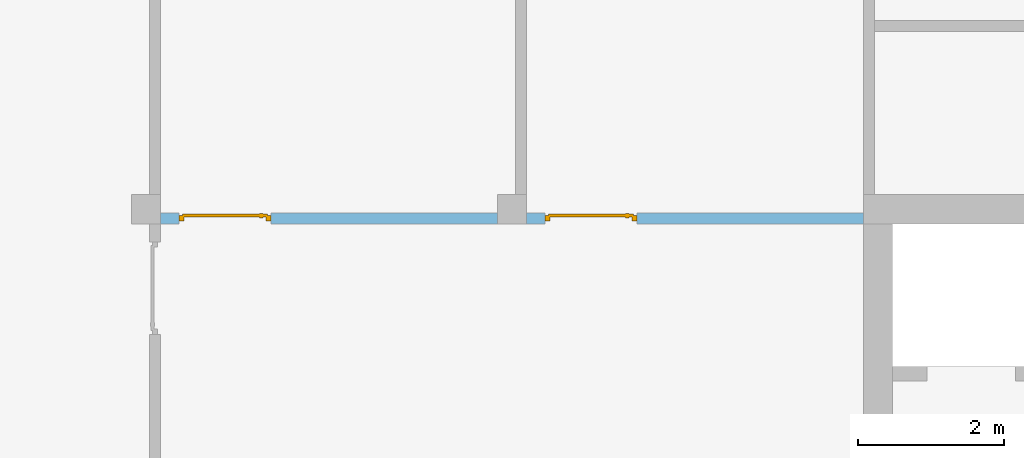
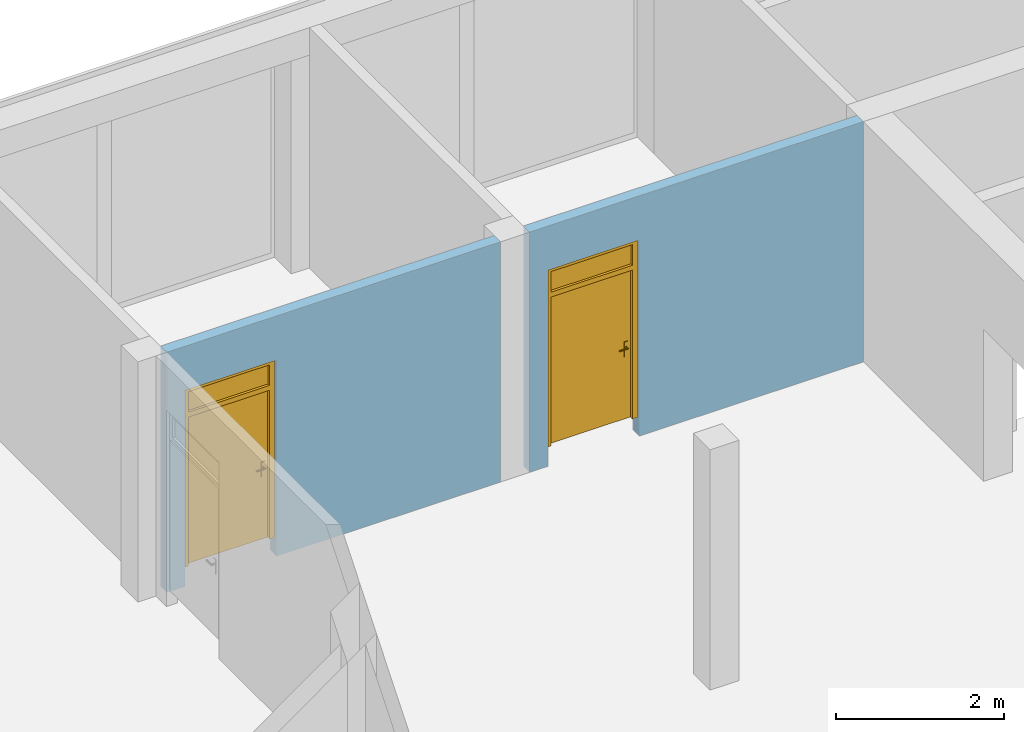
# One storey, part 3 of 6: 2 doors, 2 openings, plus 2 elements that do not belong to this part.
"""IFC2X3 building model written with IfcOpenShell, lengths in metres."""

from ifc_helpers import new_model, entity, si_unit, converted_unit, frame, frame_2d, origin, origin_with_axes, place, context, subcontext, project, spatial, polyline, rectangle, outline, extrude, closed_shell, open_shell, surface_model, source, transform, mapped, material, layer, layer_set, layer_usage, type_object, element, fill, save


model = new_model("IFC2X3")

# Units and contexts
model_context = context("Model", 3, precision=1e-05, world=origin())
body_context = subcontext(model_context, "Body", "Model", "MODEL_VIEW")
ifc_project = project(units=[si_unit("LENGTHUNIT", "METRE"), si_unit("AREAUNIT", "SQUARE_METRE"), si_unit("VOLUMEUNIT", "CUBIC_METRE"), si_unit("MASSUNIT", "GRAM", prefix="KILO"), converted_unit("PLANEANGLEUNIT", "DEGREE", entity("IfcPlaneAngleMeasure", 0.0174532925199433), si_unit("PLANEANGLEUNIT", "RADIAN"), dimensions=[0, 0, 0, 0, 0, 0, 0])], contexts=[model_context])

# Site, building, storey
site_placement = place(None, origin())
site = spatial("IfcSite", under=ifc_project, at=site_placement, CompositionType="ELEMENT")
building_placement = place(site_placement, origin())
building = spatial("IfcBuilding", under=site, at=building_placement, CompositionType="ELEMENT")
storey_placement = place(building_placement, frame((0.0, 0.0, 8.6)))
storey = spatial("IfcBuildingStorey", under=building, at=storey_placement, Name="2. Obergeschoss", CompositionType="ELEMENT", Elevation=8.6)

# Wall, opening, door
ifc_material_1 = material()
ifc_layer_1 = layer(ifc_material_1, 0.15)
ifc_layer_set_1 = layer_set([ifc_layer_1])
ifc_layer_usage_1 = layer_usage(ifc_layer_set_1, "AXIS2", "POSITIVE", -0.15)
wall_1_placement = place(storey_placement, frame((15.0, 15.15, 0.0), z_axis=(0.0, 0.0, 1.0), x_axis=(-1.0, 0.0, 0.0)))
wall_1 = element("IfcWallStandardCase", 1, at=wall_1_placement, inside=storey, material=ifc_layer_usage_1, context=body_context, shape_type="SweptSolid", body=[
    extrude(rectangle(XDim=4.6, YDim=0.15, at=frame_2d((2.3, 0.075), x_axis=(1.0, 0.0))), origin_with_axes(), (0.0, 0.0, 1.0), 3.5),
])
opening_1_placement = place(wall_1_placement, frame((4.35, 0.15, 0.0), z_axis=(0.0, -1.0, 0.0), x_axis=(0.0, 0.0, 1.0)))
opening_1 = element("IfcOpeningElement", 2, at=opening_1_placement, cuts=wall_1, ObjectType="Opening", context=body_context, shape_type="SweptSolid", body=[
    extrude(outline(polyline([(0.0, 1.26), (2.86, 1.26), (2.86, 0.0), (0.0, 0.0), (0.0, 1.26)])), origin_with_axes(), (0.0, 0.0, 1.0), 0.15),
])
ifc_material_2 = material()
door_style_1 = type_object("IfcDoorStyle", ConstructionType="NOTDEFINED", OperationType="SINGLE_SWING_RIGHT", ParameterTakesPrecedence=False, Sizeable=False)
shared_shape_1 = source(origin_with_axes(), body_context, "Body", "SurfaceModel", [
    surface_model("IfcShellBasedSurfaceModel", [(1.26, 0.07, 2.86), (1.19, 0.07, 2.86), (1.19, 0.07, 0.25), (1.26, 0.07, 0.25), (1.26, 0.0, 0.25), (1.19, 0.0, 0.25), (1.19, 0.0, 2.86), (1.26, 0.0, 2.86)], [closed_shell([[[0, 1, 2, 3]], [[4, 5, 6, 7]], [[3, 4, 7, 0]], [[2, 5, 4, 3]], [[1, 6, 5, 2]], [[0, 7, 6, 1]]], orient=[[False], [False], [False], [False], [False], [False]])]),
    surface_model("IfcShellBasedSurfaceModel", [(0.07, 0.07, 2.86), (0.0, 0.07, 2.86), (0.0, 0.07, 0.25), (0.07, 0.07, 0.25), (0.07, 0.0, 0.25), (0.0, 0.0, 0.25), (0.0, 0.0, 2.86), (0.07, 0.0, 2.86)], [closed_shell([[[0, 1, 2, 3]], [[4, 5, 6, 7]], [[3, 4, 7, 0]], [[2, 5, 4, 3]], [[1, 6, 5, 2]], [[0, 7, 6, 1]]], orient=[[False], [False], [False], [False], [False], [False]])]),
    surface_model("IfcShellBasedSurfaceModel", [(1.19, 0.07, 2.86), (0.07, 0.07, 2.86), (0.07, 0.07, 2.79), (1.19, 0.07, 2.79), (1.19, 0.0, 2.79), (0.07, 0.0, 2.79), (0.07, 0.0, 2.86), (1.19, 0.0, 2.86)], [closed_shell([[[0, 1, 2, 3]], [[4, 5, 6, 7]], [[3, 4, 7, 0]], [[2, 5, 4, 3]], [[1, 6, 5, 2]], [[0, 7, 6, 1]]], orient=[[False], [False], [False], [False], [False], [False]])]),
    surface_model("IfcShellBasedSurfaceModel", [(1.19, 0.07, 2.49), (0.07, 0.07, 2.49), (0.07, 0.07, 2.42), (1.19, 0.07, 2.42), (1.19, 0.0, 2.42), (0.07, 0.0, 2.42), (0.07, 0.0, 2.49), (1.19, 0.0, 2.49)], [closed_shell([[[0, 1, 2, 3]], [[4, 5, 6, 7]], [[3, 4, 7, 0]], [[2, 5, 4, 3]], [[1, 6, 5, 2]], [[0, 7, 6, 1]]], orient=[[False], [False], [False], [False], [False], [False]])]),
    surface_model("IfcShellBasedSurfaceModel", [(1.21, 0.09, 2.44), (0.05, 0.09, 2.44), (0.05, 0.09, 0.25), (1.21, 0.09, 0.25), (1.21, 0.05, 0.25), (0.05, 0.05, 0.25), (0.05, 0.05, 2.44), (1.21, 0.05, 2.44)], [closed_shell([[[0, 1, 2, 3]], [[4, 5, 6, 7]], [[3, 4, 7, 0]], [[2, 5, 4, 3]], [[1, 6, 5, 2]], [[0, 7, 6, 1]]], orient=[[False], [False], [False], [False], [False], [False]])]),
    surface_model("IfcShellBasedSurfaceModel", [(1.15, 0.05, 1.375), (1.1, 0.05, 1.375), (1.1, 0.05, 1.16), (1.15, 0.05, 1.16), (1.15, 0.04, 1.16), (1.1, 0.04, 1.16), (1.1, 0.04, 1.375), (1.15, 0.04, 1.375)], [closed_shell([[[0, 1, 2, 3]], [[4, 5, 6, 7]], [[3, 4, 7, 0]], [[2, 5, 4, 3]], [[1, 6, 5, 2]], [[0, 7, 6, 1]]], orient=[[False], [False], [False], [False], [False], [False]])]),
    surface_model("IfcShellBasedSurfaceModel", [(1.125, 0.04, 1.31), (1.12, 0.04, 1.30866025403784), (1.11633974596216, 0.04, 1.305), (1.115, 0.04, 1.3), (1.11633974596216, 0.04, 1.295), (1.12, 0.04, 1.29133974596216), (1.125, 0.04, 1.29), (1.13, 0.04, 1.29133974596216), (1.13366025403784, 0.04, 1.295), (1.135, 0.04, 1.3), (1.13366025403784, 0.04, 1.305), (1.13, 0.04, 1.30866025403784), (1.13, -0.005, 1.30866025403784), (1.125, 0.0, 1.31), (1.13366025403784, -0.00866025403784442, 1.305), (1.135, -0.01, 1.3), (1.13366025403784, -0.00866025403784442, 1.295), (1.13, -0.005, 1.29133974596216), (1.125, 0.0, 1.29), (1.12, 0.005, 1.29133974596216), (1.11633974596216, 0.00866025403784442, 1.295), (1.115, 0.01, 1.3), (1.11633974596216, 0.00866025403784442, 1.305), (1.12, 0.005, 1.30866025403784), (1.01, 0.0, 1.31), (1.01, -0.005, 1.30866025403784), (1.01, -0.00866025403784442, 1.305), (1.01, -0.01, 1.3), (1.01, -0.00866025403784442, 1.295), (1.01, -0.005, 1.29133974596216), (1.01, 0.0, 1.29), (1.01, 0.005, 1.29133974596216), (1.01, 0.00866025403784442, 1.295), (1.01, 0.01, 1.3), (1.01, 0.00866025403784442, 1.305), (1.01, 0.005, 1.30866025403784)], [closed_shell([[[0, 1, 2, 3, 4, 5, 6, 7, 8, 9, 10, 11]], [[0, 11, 12, 13]], [[11, 10, 14, 12]], [[10, 9, 15, 14]], [[9, 8, 16, 15]], [[8, 7, 17, 16]], [[7, 6, 18, 17]], [[6, 5, 19, 18]], [[5, 4, 20, 19]], [[4, 3, 21, 20]], [[3, 2, 22, 21]], [[2, 1, 23, 22]], [[1, 0, 13, 23]], [[24, 25, 26, 27, 28, 29, 30, 31, 32, 33, 34, 35]], [[13, 12, 25, 24]], [[12, 14, 26, 25]], [[14, 15, 27, 26]], [[15, 16, 28, 27]], [[16, 17, 29, 28]], [[17, 18, 30, 29]], [[18, 19, 31, 30]], [[19, 20, 32, 31]], [[20, 21, 33, 32]], [[21, 22, 34, 33]], [[22, 23, 35, 34]], [[23, 13, 24, 35]]], orient=[[False], [False], [False], [False], [False], [False], [False], [False], [False], [False], [False], [False], [False], [False], [False], [False], [False], [False], [False], [False], [False], [False], [False], [False], [False], [False]])]),
    surface_model("IfcShellBasedSurfaceModel", [(1.15, 0.09, 1.375), (1.15, 0.09, 1.16), (1.1, 0.09, 1.16), (1.1, 0.09, 1.375), (1.15, 0.1, 1.16), (1.15, 0.1, 1.375), (1.1, 0.1, 1.375), (1.1, 0.1, 1.16)], [closed_shell([[[0, 1, 2, 3]], [[4, 5, 6, 7]], [[1, 0, 5, 4]], [[2, 1, 4, 7]], [[3, 2, 7, 6]], [[0, 3, 6, 5]]], orient=[[False], [False], [False], [False], [False], [False]])]),
    surface_model("IfcShellBasedSurfaceModel", [(1.125, 0.1, 1.31), (1.13, 0.1, 1.30866025403784), (1.13366025403784, 0.1, 1.305), (1.135, 0.1, 1.3), (1.13366025403784, 0.1, 1.295), (1.13, 0.1, 1.29133974596216), (1.125, 0.1, 1.29), (1.12, 0.1, 1.29133974596216), (1.11633974596216, 0.1, 1.295), (1.115, 0.1, 1.3), (1.11633974596216, 0.1, 1.305), (1.12, 0.1, 1.30866025403784), (1.125, 0.14, 1.31), (1.13, 0.145, 1.30866025403784), (1.13366025403784, 0.148660254037844, 1.305), (1.135, 0.15, 1.3), (1.13366025403784, 0.148660254037844, 1.295), (1.13, 0.145, 1.29133974596216), (1.125, 0.14, 1.29), (1.12, 0.135, 1.29133974596216), (1.11633974596216, 0.131339745962156, 1.295), (1.115, 0.13, 1.3), (1.11633974596216, 0.131339745962156, 1.305), (1.12, 0.135, 1.30866025403784), (1.01, 0.14, 1.31), (1.01, 0.135, 1.30866025403784), (1.01, 0.131339745962156, 1.305), (1.01, 0.13, 1.3), (1.01, 0.131339745962156, 1.295), (1.01, 0.135, 1.29133974596216), (1.01, 0.14, 1.29), (1.01, 0.145, 1.29133974596216), (1.01, 0.148660254037844, 1.295), (1.01, 0.15, 1.3), (1.01, 0.148660254037844, 1.305), (1.01, 0.145, 1.30866025403784)], [closed_shell([[[0, 1, 2, 3, 4, 5, 6, 7, 8, 9, 10, 11]], [[0, 12, 13, 1]], [[1, 13, 14, 2]], [[2, 14, 15, 3]], [[3, 15, 16, 4]], [[4, 16, 17, 5]], [[5, 17, 18, 6]], [[6, 18, 19, 7]], [[7, 19, 20, 8]], [[8, 20, 21, 9]], [[9, 21, 22, 10]], [[10, 22, 23, 11]], [[11, 23, 12, 0]], [[24, 25, 26, 27, 28, 29, 30, 31, 32, 33, 34, 35]], [[12, 24, 35, 13]], [[13, 35, 34, 14]], [[14, 34, 33, 15]], [[15, 33, 32, 16]], [[16, 32, 31, 17]], [[17, 31, 30, 18]], [[18, 30, 29, 19]], [[19, 29, 28, 20]], [[20, 28, 27, 21]], [[21, 27, 26, 22]], [[22, 26, 25, 23]], [[23, 25, 24, 12]]], orient=[[False], [False], [False], [False], [False], [False], [False], [False], [False], [False], [False], [False], [False], [False], [False], [False], [False], [False], [False], [False], [False], [False], [False], [False], [False], [False]])]),
    surface_model("IfcShellBasedSurfaceModel", [(1.19, 0.035, 2.49), (1.19, 0.035, 2.79), (0.07, 0.035, 2.79), (0.07, 0.035, 2.49)], [open_shell([[[0, 1, 2, 3]]], orient=[[False]])]),
])
door_1_placement = place(opening_1_placement, frame((0.0, 0.0, 0.04), z_axis=(1.0, 0.0, 0.0), x_axis=(0.0, 1.0, 0.0)))
door_1 = element("IfcDoor", 3, at=door_1_placement, inside=storey, type_object=door_style_1, material=ifc_material_2, OverallHeight=2.86, OverallWidth=1.26, context=body_context, shape_type="MappedRepresentation", body=[
    mapped(shared_shape_1, transform((0.0, 0.0, 0.0), x_axis=(1.0, 0.0, 0.0), y_axis=(0.0, 1.0, 0.0), z_axis=(0.0, 0.0, 1.0), scale=1.0)),
])
fill(opening_1, door_1)

ifc_material_3 = material()
ifc_layer_2 = layer(ifc_material_3, 0.15)
ifc_layer_set_2 = layer_set([ifc_layer_2])
ifc_layer_usage_2 = layer_usage(ifc_layer_set_2, "AXIS2", "POSITIVE", -0.15)
wall_2_placement = place(storey_placement, frame((20.0, 15.15, 0.0), z_axis=(0.0, 0.0, 1.0), x_axis=(-1.0, 0.0, 0.0)))
wall_2 = element("IfcWallStandardCase", 4, at=wall_2_placement, inside=storey, material=ifc_layer_usage_2, context=body_context, shape_type="SweptSolid", body=[
    extrude(rectangle(XDim=4.6, YDim=0.15, at=frame_2d((2.3, 0.075), x_axis=(1.0, 0.0))), origin_with_axes(), (0.0, 0.0, 1.0), 3.5),
])
opening_2_placement = place(wall_2_placement, frame((4.35, 0.15, 0.0), z_axis=(0.0, -1.0, 0.0), x_axis=(0.0, 0.0, 1.0)))
opening_2 = element("IfcOpeningElement", 5, at=opening_2_placement, cuts=wall_2, ObjectType="Opening", context=body_context, shape_type="SweptSolid", body=[
    extrude(outline(polyline([(0.0, 1.26), (2.86, 1.26), (2.86, 0.0), (0.0, 0.0), (0.0, 1.26)])), origin_with_axes(), (0.0, 0.0, 1.0), 0.15),
])
ifc_material_4 = material()
door_style_2 = type_object("IfcDoorStyle", ConstructionType="NOTDEFINED", OperationType="SINGLE_SWING_RIGHT", ParameterTakesPrecedence=False, Sizeable=False)
shared_shape_2 = source(origin_with_axes(), body_context, "Body", "SurfaceModel", [
    surface_model("IfcShellBasedSurfaceModel", [(1.26, 0.07, 2.86), (1.19, 0.07, 2.86), (1.19, 0.07, 0.25), (1.26, 0.07, 0.25), (1.26, 0.0, 0.25), (1.19, 0.0, 0.25), (1.19, 0.0, 2.86), (1.26, 0.0, 2.86)], [closed_shell([[[0, 1, 2, 3]], [[4, 5, 6, 7]], [[3, 4, 7, 0]], [[2, 5, 4, 3]], [[1, 6, 5, 2]], [[0, 7, 6, 1]]], orient=[[False], [False], [False], [False], [False], [False]])]),
    surface_model("IfcShellBasedSurfaceModel", [(0.07, 0.07, 2.86), (0.0, 0.07, 2.86), (0.0, 0.07, 0.25), (0.07, 0.07, 0.25), (0.07, 0.0, 0.25), (0.0, 0.0, 0.25), (0.0, 0.0, 2.86), (0.07, 0.0, 2.86)], [closed_shell([[[0, 1, 2, 3]], [[4, 5, 6, 7]], [[3, 4, 7, 0]], [[2, 5, 4, 3]], [[1, 6, 5, 2]], [[0, 7, 6, 1]]], orient=[[False], [False], [False], [False], [False], [False]])]),
    surface_model("IfcShellBasedSurfaceModel", [(1.19, 0.07, 2.86), (0.07, 0.07, 2.86), (0.07, 0.07, 2.79), (1.19, 0.07, 2.79), (1.19, 0.0, 2.79), (0.07, 0.0, 2.79), (0.07, 0.0, 2.86), (1.19, 0.0, 2.86)], [closed_shell([[[0, 1, 2, 3]], [[4, 5, 6, 7]], [[3, 4, 7, 0]], [[2, 5, 4, 3]], [[1, 6, 5, 2]], [[0, 7, 6, 1]]], orient=[[False], [False], [False], [False], [False], [False]])]),
    surface_model("IfcShellBasedSurfaceModel", [(1.19, 0.07, 2.49), (0.07, 0.07, 2.49), (0.07, 0.07, 2.42), (1.19, 0.07, 2.42), (1.19, 0.0, 2.42), (0.07, 0.0, 2.42), (0.07, 0.0, 2.49), (1.19, 0.0, 2.49)], [closed_shell([[[0, 1, 2, 3]], [[4, 5, 6, 7]], [[3, 4, 7, 0]], [[2, 5, 4, 3]], [[1, 6, 5, 2]], [[0, 7, 6, 1]]], orient=[[False], [False], [False], [False], [False], [False]])]),
    surface_model("IfcShellBasedSurfaceModel", [(1.21, 0.09, 2.44), (0.05, 0.09, 2.44), (0.05, 0.09, 0.25), (1.21, 0.09, 0.25), (1.21, 0.05, 0.25), (0.05, 0.05, 0.25), (0.05, 0.05, 2.44), (1.21, 0.05, 2.44)], [closed_shell([[[0, 1, 2, 3]], [[4, 5, 6, 7]], [[3, 4, 7, 0]], [[2, 5, 4, 3]], [[1, 6, 5, 2]], [[0, 7, 6, 1]]], orient=[[False], [False], [False], [False], [False], [False]])]),
    surface_model("IfcShellBasedSurfaceModel", [(1.15, 0.05, 1.375), (1.1, 0.05, 1.375), (1.1, 0.05, 1.16), (1.15, 0.05, 1.16), (1.15, 0.04, 1.16), (1.1, 0.04, 1.16), (1.1, 0.04, 1.375), (1.15, 0.04, 1.375)], [closed_shell([[[0, 1, 2, 3]], [[4, 5, 6, 7]], [[3, 4, 7, 0]], [[2, 5, 4, 3]], [[1, 6, 5, 2]], [[0, 7, 6, 1]]], orient=[[False], [False], [False], [False], [False], [False]])]),
    surface_model("IfcShellBasedSurfaceModel", [(1.125, 0.04, 1.31), (1.12, 0.04, 1.30866025403784), (1.11633974596216, 0.04, 1.305), (1.115, 0.04, 1.3), (1.11633974596216, 0.04, 1.295), (1.12, 0.04, 1.29133974596216), (1.125, 0.04, 1.29), (1.13, 0.04, 1.29133974596216), (1.13366025403784, 0.04, 1.295), (1.135, 0.04, 1.3), (1.13366025403784, 0.04, 1.305), (1.13, 0.04, 1.30866025403784), (1.13, -0.005, 1.30866025403784), (1.125, 0.0, 1.31), (1.13366025403784, -0.00866025403784442, 1.305), (1.135, -0.01, 1.3), (1.13366025403784, -0.00866025403784442, 1.295), (1.13, -0.005, 1.29133974596216), (1.125, 0.0, 1.29), (1.12, 0.005, 1.29133974596216), (1.11633974596216, 0.00866025403784442, 1.295), (1.115, 0.01, 1.3), (1.11633974596216, 0.00866025403784442, 1.305), (1.12, 0.005, 1.30866025403784), (1.01, 0.0, 1.31), (1.01, -0.005, 1.30866025403784), (1.01, -0.00866025403784442, 1.305), (1.01, -0.01, 1.3), (1.01, -0.00866025403784442, 1.295), (1.01, -0.005, 1.29133974596216), (1.01, 0.0, 1.29), (1.01, 0.005, 1.29133974596216), (1.01, 0.00866025403784442, 1.295), (1.01, 0.01, 1.3), (1.01, 0.00866025403784442, 1.305), (1.01, 0.005, 1.30866025403784)], [closed_shell([[[0, 1, 2, 3, 4, 5, 6, 7, 8, 9, 10, 11]], [[0, 11, 12, 13]], [[11, 10, 14, 12]], [[10, 9, 15, 14]], [[9, 8, 16, 15]], [[8, 7, 17, 16]], [[7, 6, 18, 17]], [[6, 5, 19, 18]], [[5, 4, 20, 19]], [[4, 3, 21, 20]], [[3, 2, 22, 21]], [[2, 1, 23, 22]], [[1, 0, 13, 23]], [[24, 25, 26, 27, 28, 29, 30, 31, 32, 33, 34, 35]], [[13, 12, 25, 24]], [[12, 14, 26, 25]], [[14, 15, 27, 26]], [[15, 16, 28, 27]], [[16, 17, 29, 28]], [[17, 18, 30, 29]], [[18, 19, 31, 30]], [[19, 20, 32, 31]], [[20, 21, 33, 32]], [[21, 22, 34, 33]], [[22, 23, 35, 34]], [[23, 13, 24, 35]]], orient=[[False], [False], [False], [False], [False], [False], [False], [False], [False], [False], [False], [False], [False], [False], [False], [False], [False], [False], [False], [False], [False], [False], [False], [False], [False], [False]])]),
    surface_model("IfcShellBasedSurfaceModel", [(1.15, 0.09, 1.375), (1.15, 0.09, 1.16), (1.1, 0.09, 1.16), (1.1, 0.09, 1.375), (1.15, 0.1, 1.16), (1.15, 0.1, 1.375), (1.1, 0.1, 1.375), (1.1, 0.1, 1.16)], [closed_shell([[[0, 1, 2, 3]], [[4, 5, 6, 7]], [[1, 0, 5, 4]], [[2, 1, 4, 7]], [[3, 2, 7, 6]], [[0, 3, 6, 5]]], orient=[[False], [False], [False], [False], [False], [False]])]),
    surface_model("IfcShellBasedSurfaceModel", [(1.125, 0.1, 1.31), (1.13, 0.1, 1.30866025403784), (1.13366025403784, 0.1, 1.305), (1.135, 0.1, 1.3), (1.13366025403784, 0.1, 1.295), (1.13, 0.1, 1.29133974596216), (1.125, 0.1, 1.29), (1.12, 0.1, 1.29133974596216), (1.11633974596216, 0.1, 1.295), (1.115, 0.1, 1.3), (1.11633974596216, 0.1, 1.305), (1.12, 0.1, 1.30866025403784), (1.125, 0.14, 1.31), (1.13, 0.145, 1.30866025403784), (1.13366025403784, 0.148660254037844, 1.305), (1.135, 0.15, 1.3), (1.13366025403784, 0.148660254037844, 1.295), (1.13, 0.145, 1.29133974596216), (1.125, 0.14, 1.29), (1.12, 0.135, 1.29133974596216), (1.11633974596216, 0.131339745962156, 1.295), (1.115, 0.13, 1.3), (1.11633974596216, 0.131339745962156, 1.305), (1.12, 0.135, 1.30866025403784), (1.01, 0.14, 1.31), (1.01, 0.135, 1.30866025403784), (1.01, 0.131339745962156, 1.305), (1.01, 0.13, 1.3), (1.01, 0.131339745962156, 1.295), (1.01, 0.135, 1.29133974596216), (1.01, 0.14, 1.29), (1.01, 0.145, 1.29133974596216), (1.01, 0.148660254037844, 1.295), (1.01, 0.15, 1.3), (1.01, 0.148660254037844, 1.305), (1.01, 0.145, 1.30866025403784)], [closed_shell([[[0, 1, 2, 3, 4, 5, 6, 7, 8, 9, 10, 11]], [[0, 12, 13, 1]], [[1, 13, 14, 2]], [[2, 14, 15, 3]], [[3, 15, 16, 4]], [[4, 16, 17, 5]], [[5, 17, 18, 6]], [[6, 18, 19, 7]], [[7, 19, 20, 8]], [[8, 20, 21, 9]], [[9, 21, 22, 10]], [[10, 22, 23, 11]], [[11, 23, 12, 0]], [[24, 25, 26, 27, 28, 29, 30, 31, 32, 33, 34, 35]], [[12, 24, 35, 13]], [[13, 35, 34, 14]], [[14, 34, 33, 15]], [[15, 33, 32, 16]], [[16, 32, 31, 17]], [[17, 31, 30, 18]], [[18, 30, 29, 19]], [[19, 29, 28, 20]], [[20, 28, 27, 21]], [[21, 27, 26, 22]], [[22, 26, 25, 23]], [[23, 25, 24, 12]]], orient=[[False], [False], [False], [False], [False], [False], [False], [False], [False], [False], [False], [False], [False], [False], [False], [False], [False], [False], [False], [False], [False], [False], [False], [False], [False], [False]])]),
    surface_model("IfcShellBasedSurfaceModel", [(1.19, 0.035, 2.49), (1.19, 0.035, 2.79), (0.07, 0.035, 2.79), (0.07, 0.035, 2.49)], [open_shell([[[0, 1, 2, 3]]], orient=[[False]])]),
])
door_2_placement = place(opening_2_placement, frame((0.0, 0.0, 0.04), z_axis=(1.0, 0.0, 0.0), x_axis=(0.0, 1.0, 0.0)))
door_2 = element("IfcDoor", 6, at=door_2_placement, inside=storey, type_object=door_style_2, material=ifc_material_4, OverallHeight=2.86, OverallWidth=1.26, context=body_context, shape_type="MappedRepresentation", body=[
    mapped(shared_shape_2, transform((0.0, 0.0, 0.0), x_axis=(1.0, 0.0, 0.0), y_axis=(0.0, 1.0, 0.0), z_axis=(0.0, 0.0, 1.0), scale=1.0)),
])
fill(opening_2, door_2)

save(model, "model.ifc")
